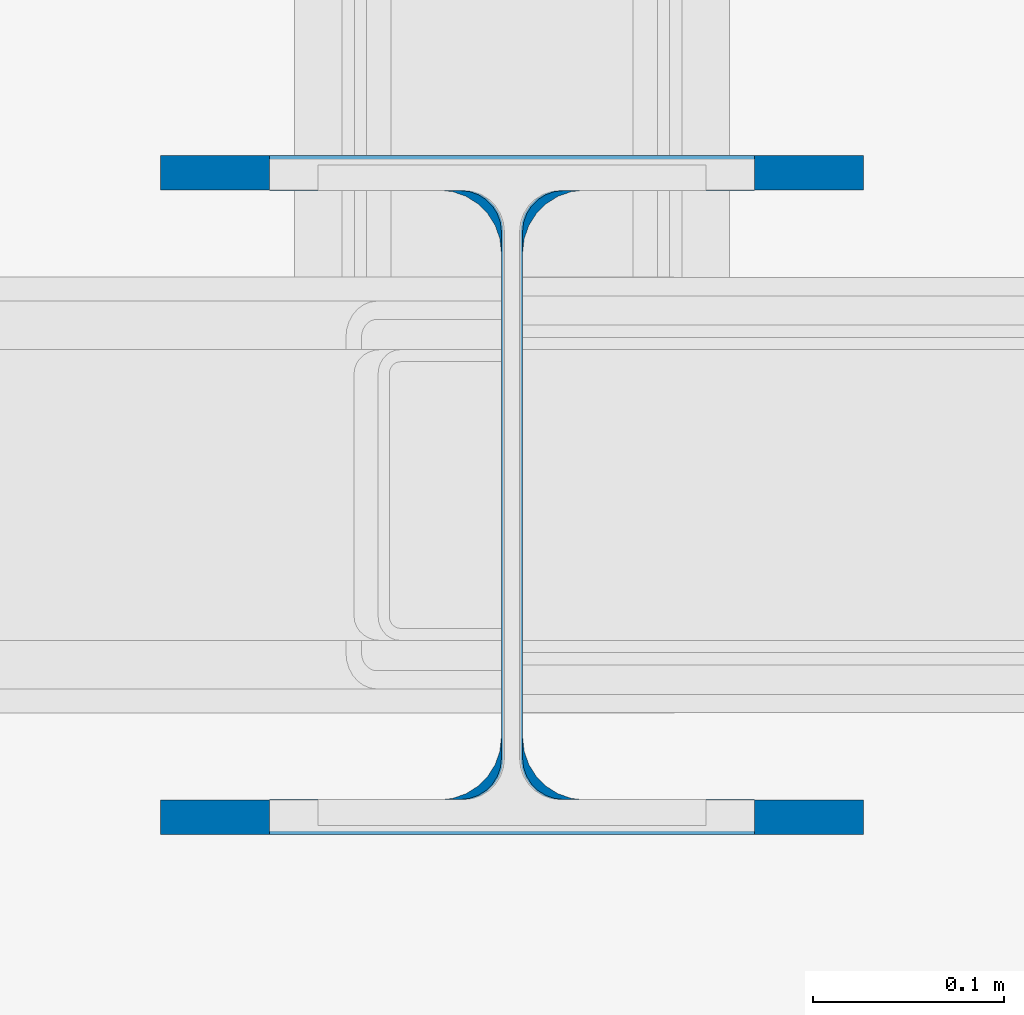
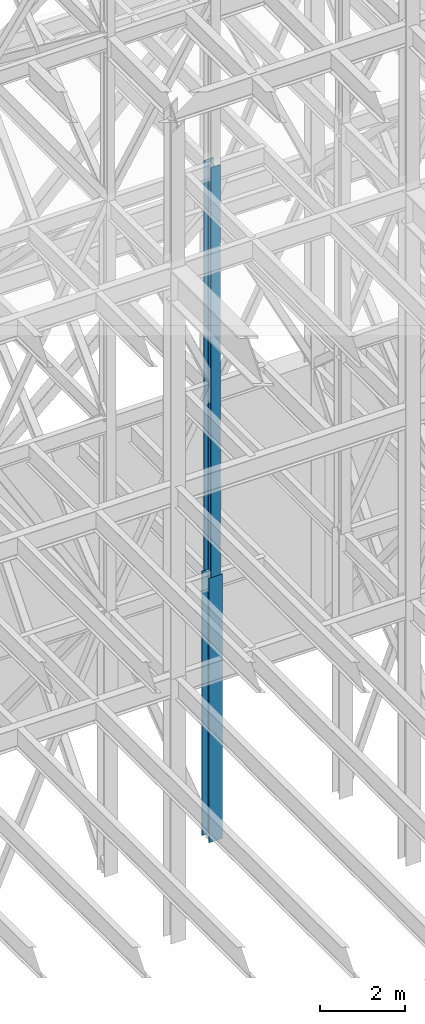
# One storey, part 47 of 150: 2 columns.
"""IFC2X3 building model written with IfcOpenShell, lengths in millimetres."""

from ifc_helpers import new_model, si_unit, frame, origin_with_axes, origin_2d_with_axis, place, context, subcontext, project, spatial, i_section, extrude, material, type_object, element, save


model = new_model("IFC2X3")

# Units and contexts
model_context = context("Model", 3, precision=1e-05, world=origin_with_axes())
body_context = subcontext(model_context, "Body", "Model", "MODEL_VIEW")
ifc_project = project(units=[si_unit("LENGTHUNIT", "METRE", prefix="MILLI"), si_unit("AREAUNIT", "SQUARE_METRE"), si_unit("VOLUMEUNIT", "CUBIC_METRE"), si_unit("MASSUNIT", "GRAM", prefix="KILO"), si_unit("TIMEUNIT", "SECOND"), si_unit("PLANEANGLEUNIT", "RADIAN"), si_unit("SOLIDANGLEUNIT", "STERADIAN"), si_unit("THERMODYNAMICTEMPERATUREUNIT", "DEGREE_CELSIUS"), si_unit("LUMINOUSINTENSITYUNIT", "LUMEN")], contexts=[model_context])

# Site, building, storey
site_placement = place(None, origin_with_axes())
site = spatial("IfcSite", under=ifc_project, at=site_placement, CompositionType="ELEMENT")
building_placement = place(site_placement, origin_with_axes())
building = spatial("IfcBuilding", under=site, at=building_placement, Name="Undefined", CompositionType="ELEMENT")
storey_placement = place(building_placement, origin_with_axes())
storey = spatial("IfcBuildingStorey", under=building, at=storey_placement, Name="Undefined", CompositionType="ELEMENT", Elevation=0.0)

# Columns
ifc_material = material(Name="STEEL/A992")
column_type_1 = type_object("IfcColumnType", Name="W14X68", PredefinedType="NOTDEFINED")
column_1_placement = place(storey_placement, frame((59436.0, 25628.6, 23774.4), z_axis=(0.0, 0.0, 1.0), x_axis=(1.0, 0.0, 0.0)))
element("IfcColumn", 1, at=column_1_placement, inside=storey, type_object=column_type_1, material=ifc_material, Name="COLUMN", ObjectType="W14X68", context=body_context, shape_type="SweptSolid", body=[
    extrude(i_section(OverallWidth=254.0, OverallDepth=355.6, WebThickness=11.1125, FlangeThickness=18.288, FilletRadius=21.3994, at=origin_2d_with_axis()), frame((0.0, 0.0, 11811.0), z_axis=(0.0, 0.0, -1.0), x_axis=(-1.0, 0.0, 0.0)), (0.0, 0.0, 1.0), 11811.0),
])
column_type_2 = type_object("IfcColumnType", Name="W14X90", PredefinedType="NOTDEFINED")
column_2_placement = place(storey_placement, frame((59436.0, 25628.6, 16154.4), z_axis=(0.0, 0.0, 1.0), x_axis=(1.0, 0.0, 0.0)))
element("IfcColumn", 2, at=column_2_placement, inside=storey, type_object=column_type_2, material=ifc_material, Name="COLUMN", ObjectType="W14X90", context=body_context, shape_type="SweptSolid", body=[
    extrude(i_section(OverallWidth=368.3, OverallDepth=355.6, WebThickness=11.1125, FlangeThickness=18.034, FilletRadius=32.7659, at=origin_2d_with_axis()), frame((0.0, 0.0, 7620.0), z_axis=(0.0, 0.0, -1.0), x_axis=(-1.0, 0.0, 0.0)), (0.0, 0.0, 1.0), 7620.0),
])

save(model, "model.ifc")
